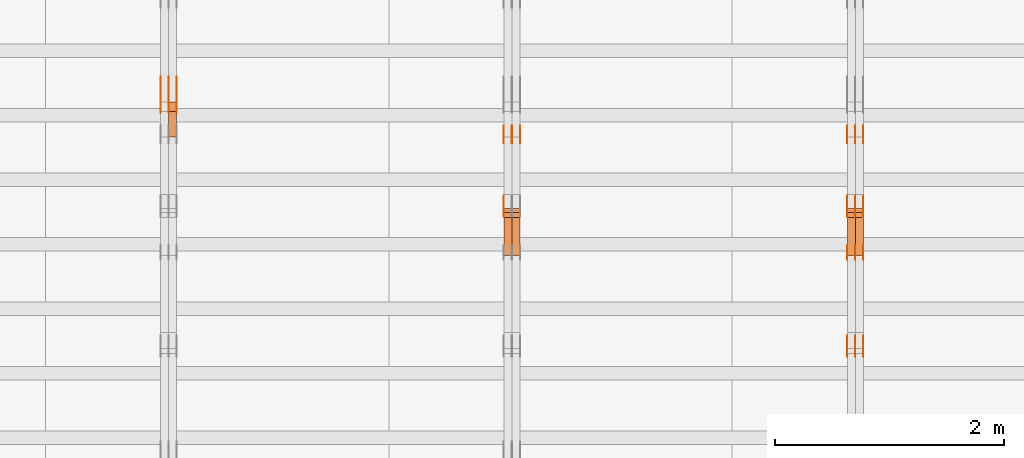
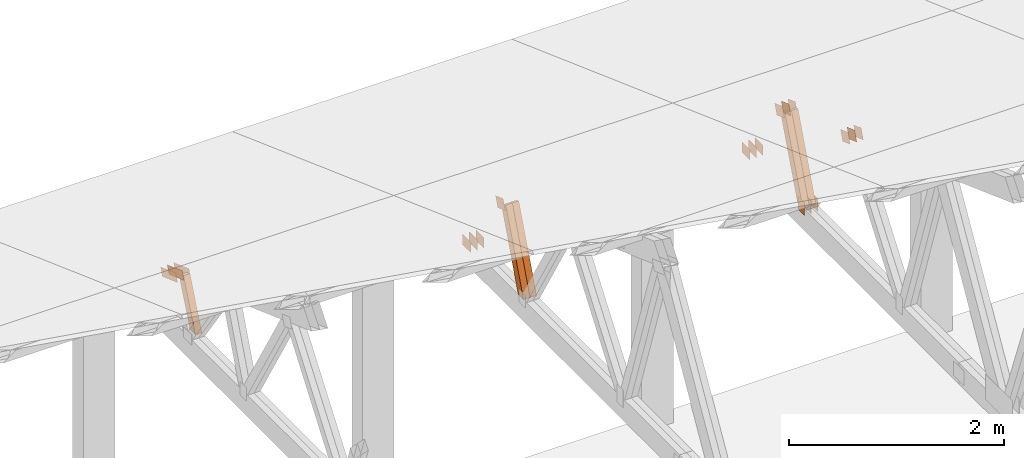
# One storey, part 133 of 189: 30 proxies.
"""IFC2X3 building model written with IfcOpenShell, lengths in millimetres."""

from ifc_helpers import new_model, entity, si_unit, converted_unit, derived_unit, direction, frame, frame_2d, origin, origin_2d_with_axis, place, context, subcontext, project, spatial, polyline, rectangle, outline, extrude, source, transform, mapped, material, type_object, type_shapes, element, save


model = new_model("IFC2X3")

# Units and contexts
model_context = context("Model", 3, precision=0.01, world=origin(), true_north=direction((6.12303176911189e-17, 1.0)))
body_context = subcontext(model_context, "Body", "Model", "MODEL_VIEW")
ifc_project = project(units=[si_unit("LENGTHUNIT", "METRE", prefix="MILLI"), si_unit("AREAUNIT", "SQUARE_METRE"), si_unit("VOLUMEUNIT", "CUBIC_METRE"), converted_unit("PLANEANGLEUNIT", "DEGREE", entity("IfcRatioMeasure", 0.0174532925199433), si_unit("PLANEANGLEUNIT", "RADIAN"), dimensions=[0, 0, 0, 0, 0, 0, 0]), si_unit("MASSUNIT", "GRAM", prefix="KILO"), derived_unit("MASSDENSITYUNIT", [(si_unit("MASSUNIT", "GRAM", prefix="KILO"), 1), (si_unit("LENGTHUNIT", "METRE"), -3)]), si_unit("TIMEUNIT", "SECOND"), si_unit("FREQUENCYUNIT", "HERTZ"), si_unit("THERMODYNAMICTEMPERATUREUNIT", "DEGREE_CELSIUS"), derived_unit("THERMALTRANSMITTANCEUNIT", [(si_unit("MASSUNIT", "GRAM", prefix="KILO"), 1), (si_unit("THERMODYNAMICTEMPERATUREUNIT", "KELVIN"), -1), (si_unit("TIMEUNIT", "SECOND"), -3)]), derived_unit("VOLUMETRICFLOWRATEUNIT", [(si_unit("LENGTHUNIT", "METRE"), 3), (si_unit("TIMEUNIT", "SECOND"), -1)]), si_unit("ELECTRICCURRENTUNIT", "AMPERE"), si_unit("ELECTRICVOLTAGEUNIT", "VOLT"), si_unit("POWERUNIT", "WATT"), si_unit("FORCEUNIT", "NEWTON"), si_unit("ILLUMINANCEUNIT", "LUX"), si_unit("LUMINOUSFLUXUNIT", "LUMEN"), si_unit("LUMINOUSINTENSITYUNIT", "CANDELA"), derived_unit("USERDEFINED", [(si_unit("MASSUNIT", "GRAM", prefix="KILO"), -1), (si_unit("LENGTHUNIT", "METRE"), -2), (si_unit("TIMEUNIT", "SECOND"), 3), (si_unit("LUMINOUSFLUXUNIT", "LUMEN"), 1)]), derived_unit("LINEARVELOCITYUNIT", [(si_unit("LENGTHUNIT", "METRE"), 1), (si_unit("TIMEUNIT", "SECOND"), -1)]), si_unit("PRESSUREUNIT", "PASCAL"), derived_unit("USERDEFINED", [(si_unit("LENGTHUNIT", "METRE"), -2), (si_unit("MASSUNIT", "GRAM", prefix="KILO"), 1), (si_unit("TIMEUNIT", "SECOND"), -2)])], contexts=[model_context])

# Site, building, storey
site_placement = place(None, origin())
site = spatial("IfcSite", under=ifc_project, at=site_placement, CompositionType="ELEMENT")
building_placement = place(site_placement, origin())
building = spatial("IfcBuilding", under=site, at=building_placement, CompositionType="ELEMENT")
storey_placement = place(building_placement, origin())
storey = spatial("IfcBuildingStorey", under=building, at=storey_placement, Name="Default", CompositionType="ELEMENT", Elevation=0.0)

# Proxies
ifc_material_1 = material(Name="IfcSurfaceStyle #168726")
building_element_proxy_type_1 = type_object("IfcBuildingElementProxyType", PredefinedType="NOTDEFINED", material=ifc_material_1)
shared_shape_1 = source(origin(), body_context, "Body", "SweptSolid", [
    extrude(outline(polyline([(-74.9999475298494, -60.0), (75.0000042257432, -60.0), (74.9999684051025, 60.0), (-75.0000251009963, 60.0), (-74.9999475298494, -60.0)])), frame((75.0000607644577, 60.0000865490217, 0.0), z_axis=(0.0, 0.0, 1.0), x_axis=(-1.0, 0.0, 0.0)), (0.0, 0.0, 1.0), 1.3),
])
type_shapes(building_element_proxy_type_1, [shared_shape_1])
proxy_1_placement = place(building_placement, frame((30301.3, 25732.0586805394, 1446.84420669249), z_axis=(-1.0, 0.0, 0.0), x_axis=(0.0, -0.939692620785908, 0.342020143325669)))
element("IfcBuildingElementProxy", 1, at=proxy_1_placement, inside=storey, type_object=building_element_proxy_type_1, material=ifc_material_1, context=body_context, shape_type="MappedRepresentation", body=[
    mapped(shared_shape_1, transform((0.0, 0.0, 0.0), scale=1.0)),
])
ifc_material_2 = material(Name="IfcSurfaceStyle #168669")
building_element_proxy_type_2 = type_object("IfcBuildingElementProxyType", PredefinedType="NOTDEFINED", material=ifc_material_2)
shared_shape_2 = source(origin(), body_context, "Body", "SweptSolid", [
    extrude(outline(polyline([(-74.9999475298494, -60.0), (75.0000042257432, -60.0), (74.9999684051025, 60.0), (-75.0000251009963, 60.0), (-74.9999475298494, -60.0)])), frame((75.0000607644577, 60.0000865490217, 0.0), z_axis=(0.0, 0.0, 1.0), x_axis=(-1.0, 0.0, 0.0)), (0.0, 0.0, 1.0), 1.29999999999999),
])
type_shapes(building_element_proxy_type_2, [shared_shape_2])
proxy_2_placement = place(building_placement, frame((30230.0, 25732.0586805394, 1446.84420669249), z_axis=(-1.0, 0.0, 0.0), x_axis=(0.0, -0.939692620785908, 0.342020143325669)))
element("IfcBuildingElementProxy", 2, at=proxy_2_placement, inside=storey, type_object=building_element_proxy_type_2, material=ifc_material_2, context=body_context, shape_type="MappedRepresentation", body=[
    mapped(shared_shape_2, transform((0.0, 0.0, 0.0), scale=1.0)),
])
ifc_material_3 = material(Name="IfcSurfaceStyle #168612")
building_element_proxy_type_3 = type_object("IfcBuildingElementProxyType", PredefinedType="NOTDEFINED", material=ifc_material_3)
shared_shape_3 = source(origin(), body_context, "Body", "SweptSolid", [
    extrude(outline(polyline([(-74.9999475298494, -60.0), (75.0000042257432, -60.0), (74.9999684051025, 60.0), (-75.0000251009963, 60.0), (-74.9999475298494, -60.0)])), frame((75.0000607644577, 60.0000865490217, 0.0), z_axis=(0.0, 0.0, 1.0), x_axis=(-1.0, 0.0, 0.0)), (0.0, 0.0, 1.0), 1.29999999999999),
])
type_shapes(building_element_proxy_type_3, [shared_shape_3])
proxy_3_placement = place(building_placement, frame((30231.3, 25732.0586805394, 1446.84420669249), z_axis=(-1.0, 0.0, 0.0), x_axis=(0.0, -0.939692620785908, 0.342020143325669)))
element("IfcBuildingElementProxy", 3, at=proxy_3_placement, inside=storey, type_object=building_element_proxy_type_3, material=ifc_material_3, context=body_context, shape_type="MappedRepresentation", body=[
    mapped(shared_shape_3, transform((0.0, 0.0, 0.0), scale=1.0)),
])
ifc_material_4 = material(Name="IfcSurfaceStyle #168555")
building_element_proxy_type_4 = type_object("IfcBuildingElementProxyType", PredefinedType="NOTDEFINED", material=ifc_material_4)
shared_shape_4 = source(origin(), body_context, "Body", "SweptSolid", [
    extrude(outline(polyline([(-74.9999475298494, -60.0), (75.0000042257432, -60.0), (74.9999684051025, 60.0), (-75.0000251009963, 60.0), (-74.9999475298494, -60.0)])), frame((75.0000607644577, 60.0000865490217, 0.0), z_axis=(0.0, 0.0, 1.0), x_axis=(-1.0, 0.0, 0.0)), (0.0, 0.0, 1.0), 1.29999999999999),
])
type_shapes(building_element_proxy_type_4, [shared_shape_4])
proxy_4_placement = place(building_placement, frame((30160.0, 25732.0586805394, 1446.84420669249), z_axis=(-1.0, 0.0, 0.0), x_axis=(0.0, -0.939692620785908, 0.342020143325669)))
element("IfcBuildingElementProxy", 4, at=proxy_4_placement, inside=storey, type_object=building_element_proxy_type_4, material=ifc_material_4, context=body_context, shape_type="MappedRepresentation", body=[
    mapped(shared_shape_4, transform((0.0, 0.0, 0.0), scale=1.0)),
])
ifc_material_5 = material(Name="IfcSurfaceStyle #168498")
building_element_proxy_type_5 = type_object("IfcBuildingElementProxyType", PredefinedType="NOTDEFINED", material=ifc_material_5)
shared_shape_5 = source(origin(), body_context, "Body", "SweptSolid", [
    extrude(rectangle(XDim=150.0, YDim=120.0, at=frame_2d((-7.105427357601e-15, 0.0), x_axis=(1.0, 0.0))), frame((75.0, 60.0, 0.0), z_axis=(0.0, 0.0, 1.0), x_axis=(-1.0, 0.0, 0.0)), (0.0, 0.0, 1.0), 1.3),
])
type_shapes(building_element_proxy_type_5, [shared_shape_5])
proxy_5_placement = place(building_placement, frame((30301.3, 26439.0083007813, 170.0), z_axis=(-1.0, 0.0, 0.0), x_axis=(0.0, 0.0, 1.0)))
element("IfcBuildingElementProxy", 5, at=proxy_5_placement, inside=storey, type_object=building_element_proxy_type_5, material=ifc_material_5, context=body_context, shape_type="MappedRepresentation", body=[
    mapped(shared_shape_5, transform((0.0, 0.0, 0.0), scale=1.0)),
])
ifc_material_6 = material(Name="IfcSurfaceStyle #168441")
building_element_proxy_type_6 = type_object("IfcBuildingElementProxyType", PredefinedType="NOTDEFINED", material=ifc_material_6)
shared_shape_6 = source(origin(), body_context, "Body", "SweptSolid", [
    extrude(rectangle(XDim=150.0, YDim=120.0, at=frame_2d((-7.105427357601e-15, 0.0), x_axis=(1.0, 0.0))), frame((75.0, 60.0, 0.0), z_axis=(0.0, 0.0, 1.0), x_axis=(-1.0, 0.0, 0.0)), (0.0, 0.0, 1.0), 1.29999999999999),
])
type_shapes(building_element_proxy_type_6, [shared_shape_6])
proxy_6_placement = place(building_placement, frame((30230.0, 26439.0083007813, 170.0), z_axis=(-1.0, 0.0, 0.0), x_axis=(0.0, 0.0, 1.0)))
element("IfcBuildingElementProxy", 6, at=proxy_6_placement, inside=storey, type_object=building_element_proxy_type_6, material=ifc_material_6, context=body_context, shape_type="MappedRepresentation", body=[
    mapped(shared_shape_6, transform((0.0, 0.0, 0.0), scale=1.0)),
])
ifc_material_7 = material(Name="IfcSurfaceStyle #168384")
building_element_proxy_type_7 = type_object("IfcBuildingElementProxyType", PredefinedType="NOTDEFINED", material=ifc_material_7)
shared_shape_7 = source(origin(), body_context, "Body", "SweptSolid", [
    extrude(rectangle(XDim=150.0, YDim=120.0, at=frame_2d((-7.105427357601e-15, 0.0), x_axis=(1.0, 0.0))), frame((75.0, 60.0, 0.0), z_axis=(0.0, 0.0, 1.0), x_axis=(-1.0, 0.0, 0.0)), (0.0, 0.0, 1.0), 1.29999999999999),
])
type_shapes(building_element_proxy_type_7, [shared_shape_7])
proxy_7_placement = place(building_placement, frame((30231.3, 26439.0083007813, 170.0), z_axis=(-1.0, 0.0, 0.0), x_axis=(0.0, 0.0, 1.0)))
element("IfcBuildingElementProxy", 7, at=proxy_7_placement, inside=storey, type_object=building_element_proxy_type_7, material=ifc_material_7, context=body_context, shape_type="MappedRepresentation", body=[
    mapped(shared_shape_7, transform((0.0, 0.0, 0.0), scale=1.0)),
])
ifc_material_8 = material(Name="IfcSurfaceStyle #168327")
building_element_proxy_type_8 = type_object("IfcBuildingElementProxyType", PredefinedType="NOTDEFINED", material=ifc_material_8)
shared_shape_8 = source(origin(), body_context, "Body", "SweptSolid", [
    extrude(rectangle(XDim=150.0, YDim=120.0, at=frame_2d((-7.105427357601e-15, 0.0), x_axis=(1.0, 0.0))), frame((75.0, 60.0, 0.0), z_axis=(0.0, 0.0, 1.0), x_axis=(-1.0, 0.0, 0.0)), (0.0, 0.0, 1.0), 1.29999999999999),
])
type_shapes(building_element_proxy_type_8, [shared_shape_8])
proxy_8_placement = place(building_placement, frame((30160.0, 26439.0083007813, 170.0), z_axis=(-1.0, 0.0, 0.0), x_axis=(0.0, 0.0, 1.0)))
element("IfcBuildingElementProxy", 8, at=proxy_8_placement, inside=storey, type_object=building_element_proxy_type_8, material=ifc_material_8, context=body_context, shape_type="MappedRepresentation", body=[
    mapped(shared_shape_8, transform((0.0, 0.0, 0.0), scale=1.0)),
])
ifc_material_9 = material(Name="IfcSurfaceStyle #167814")
building_element_proxy_type_9 = type_object("IfcBuildingElementProxyType", PredefinedType="NOTDEFINED", material=ifc_material_9)
shared_shape_9 = source(origin(), body_context, "Body", "SweptSolid", [
    extrude(outline(polyline([(-74.9999684051023, -60.0), (75.0000251009964, -60.0), (74.9999475298495, 60.0), (-75.0000042257435, 60.0), (-74.9999684051023, -60.0)])), frame((75.0000251009964, 60.0000006265238, 0.0), z_axis=(0.0, 0.0, 1.0), x_axis=(-1.0, 0.0, 0.0)), (0.0, 0.0, 1.0), 1.3),
])
type_shapes(building_element_proxy_type_9, [shared_shape_9])
proxy_9_placement = place(building_placement, frame((30301.3, 26956.490053282, 1001.18769055967), z_axis=(-1.0, 0.0, 0.0), x_axis=(0.0, -0.939692620785908, 0.342020143325669)))
element("IfcBuildingElementProxy", 9, at=proxy_9_placement, inside=storey, type_object=building_element_proxy_type_9, material=ifc_material_9, context=body_context, shape_type="MappedRepresentation", body=[
    mapped(shared_shape_9, transform((0.0, 0.0, 0.0), scale=1.0)),
])
ifc_material_10 = material(Name="IfcSurfaceStyle #167757")
building_element_proxy_type_10 = type_object("IfcBuildingElementProxyType", PredefinedType="NOTDEFINED", material=ifc_material_10)
shared_shape_10 = source(origin(), body_context, "Body", "SweptSolid", [
    extrude(outline(polyline([(-74.9999684051023, -60.0), (75.0000251009964, -60.0), (74.9999475298495, 60.0), (-75.0000042257435, 60.0), (-74.9999684051023, -60.0)])), frame((75.0000251009964, 60.0000006265238, 0.0), z_axis=(0.0, 0.0, 1.0), x_axis=(-1.0, 0.0, 0.0)), (0.0, 0.0, 1.0), 1.29999999999999),
])
type_shapes(building_element_proxy_type_10, [shared_shape_10])
proxy_10_placement = place(building_placement, frame((30230.0, 26956.490053282, 1001.18769055967), z_axis=(-1.0, 0.0, 0.0), x_axis=(0.0, -0.939692620785908, 0.342020143325669)))
element("IfcBuildingElementProxy", 10, at=proxy_10_placement, inside=storey, type_object=building_element_proxy_type_10, material=ifc_material_10, context=body_context, shape_type="MappedRepresentation", body=[
    mapped(shared_shape_10, transform((0.0, 0.0, 0.0), scale=1.0)),
])
ifc_material_11 = material(Name="IfcSurfaceStyle #167700")
building_element_proxy_type_11 = type_object("IfcBuildingElementProxyType", PredefinedType="NOTDEFINED", material=ifc_material_11)
shared_shape_11 = source(origin(), body_context, "Body", "SweptSolid", [
    extrude(outline(polyline([(-74.9999684051023, -60.0), (75.0000251009964, -60.0), (74.9999475298495, 60.0), (-75.0000042257435, 60.0), (-74.9999684051023, -60.0)])), frame((75.0000251009964, 60.0000006265238, 0.0), z_axis=(0.0, 0.0, 1.0), x_axis=(-1.0, 0.0, 0.0)), (0.0, 0.0, 1.0), 1.29999999999999),
])
type_shapes(building_element_proxy_type_11, [shared_shape_11])
proxy_11_placement = place(building_placement, frame((30231.3, 26956.490053282, 1001.18769055967), z_axis=(-1.0, 0.0, 0.0), x_axis=(0.0, -0.939692620785908, 0.342020143325669)))
element("IfcBuildingElementProxy", 11, at=proxy_11_placement, inside=storey, type_object=building_element_proxy_type_11, material=ifc_material_11, context=body_context, shape_type="MappedRepresentation", body=[
    mapped(shared_shape_11, transform((0.0, 0.0, 0.0), scale=1.0)),
])
ifc_material_12 = material(Name="IfcSurfaceStyle #167643")
building_element_proxy_type_12 = type_object("IfcBuildingElementProxyType", PredefinedType="NOTDEFINED", material=ifc_material_12)
shared_shape_12 = source(origin(), body_context, "Body", "SweptSolid", [
    extrude(outline(polyline([(-74.9999684051023, -60.0), (75.0000251009964, -60.0), (74.9999475298495, 60.0), (-75.0000042257435, 60.0), (-74.9999684051023, -60.0)])), frame((75.0000251009964, 60.0000006265238, 0.0), z_axis=(0.0, 0.0, 1.0), x_axis=(-1.0, 0.0, 0.0)), (0.0, 0.0, 1.0), 1.29999999999999),
])
type_shapes(building_element_proxy_type_12, [shared_shape_12])
proxy_12_placement = place(building_placement, frame((30160.0, 26956.490053282, 1001.18769055967), z_axis=(-1.0, 0.0, 0.0), x_axis=(0.0, -0.939692620785908, 0.342020143325669)))
element("IfcBuildingElementProxy", 12, at=proxy_12_placement, inside=storey, type_object=building_element_proxy_type_12, material=ifc_material_12, context=body_context, shape_type="MappedRepresentation", body=[
    mapped(shared_shape_12, transform((0.0, 0.0, 0.0), scale=1.0)),
])
ifc_material_13 = material(Name="IfcSurfaceStyle #167586")
building_element_proxy_type_13 = type_object("IfcBuildingElementProxyType", PredefinedType="NOTDEFINED", material=ifc_material_13)
shared_shape_13 = source(origin(), body_context, "Body", "SweptSolid", [
    extrude(rectangle(XDim=150.0, YDim=120.0, at=origin_2d_with_axis()), frame((75.0, 60.0, 0.0), z_axis=(0.0, 0.0, 1.0), x_axis=(-1.0, 0.0, 0.0)), (0.0, 0.0, 1.0), 1.3),
])
type_shapes(building_element_proxy_type_13, [shared_shape_13])
proxy_13_placement = place(building_placement, frame((30301.3, 27607.3129882813, 185.0), z_axis=(-1.0, 0.0, 0.0), x_axis=(0.0, -1.0, 0.0)))
element("IfcBuildingElementProxy", 13, at=proxy_13_placement, inside=storey, type_object=building_element_proxy_type_13, material=ifc_material_13, context=body_context, shape_type="MappedRepresentation", body=[
    mapped(shared_shape_13, transform((0.0, 0.0, 0.0), scale=1.0)),
])
ifc_material_14 = material(Name="IfcSurfaceStyle #167529")
building_element_proxy_type_14 = type_object("IfcBuildingElementProxyType", PredefinedType="NOTDEFINED", material=ifc_material_14)
shared_shape_14 = source(origin(), body_context, "Body", "SweptSolid", [
    extrude(rectangle(XDim=150.0, YDim=120.0, at=origin_2d_with_axis()), frame((75.0, 60.0, 0.0), z_axis=(0.0, 0.0, 1.0), x_axis=(-1.0, 0.0, 0.0)), (0.0, 0.0, 1.0), 1.29999999999999),
])
type_shapes(building_element_proxy_type_14, [shared_shape_14])
proxy_14_placement = place(building_placement, frame((30230.0, 27607.3129882813, 185.0), z_axis=(-1.0, 0.0, 0.0), x_axis=(0.0, -1.0, 0.0)))
element("IfcBuildingElementProxy", 14, at=proxy_14_placement, inside=storey, type_object=building_element_proxy_type_14, material=ifc_material_14, context=body_context, shape_type="MappedRepresentation", body=[
    mapped(shared_shape_14, transform((0.0, 0.0, 0.0), scale=1.0)),
])
ifc_material_15 = material(Name="IfcSurfaceStyle #167472")
building_element_proxy_type_15 = type_object("IfcBuildingElementProxyType", PredefinedType="NOTDEFINED", material=ifc_material_15)
shared_shape_15 = source(origin(), body_context, "Body", "SweptSolid", [
    extrude(rectangle(XDim=150.0, YDim=120.0, at=origin_2d_with_axis()), frame((75.0, 60.0, 0.0), z_axis=(0.0, 0.0, 1.0), x_axis=(-1.0, 0.0, 0.0)), (0.0, 0.0, 1.0), 1.29999999999999),
])
type_shapes(building_element_proxy_type_15, [shared_shape_15])
proxy_15_placement = place(building_placement, frame((30231.3, 27607.3129882813, 185.0), z_axis=(-1.0, 0.0, 0.0), x_axis=(0.0, -1.0, 0.0)))
element("IfcBuildingElementProxy", 15, at=proxy_15_placement, inside=storey, type_object=building_element_proxy_type_15, material=ifc_material_15, context=body_context, shape_type="MappedRepresentation", body=[
    mapped(shared_shape_15, transform((0.0, 0.0, 0.0), scale=1.0)),
])
ifc_material_16 = material(Name="IfcSurfaceStyle #167415")
building_element_proxy_type_16 = type_object("IfcBuildingElementProxyType", PredefinedType="NOTDEFINED", material=ifc_material_16)
shared_shape_16 = source(origin(), body_context, "Body", "SweptSolid", [
    extrude(rectangle(XDim=150.0, YDim=120.0, at=origin_2d_with_axis()), frame((75.0, 60.0, 0.0), z_axis=(0.0, 0.0, 1.0), x_axis=(-1.0, 0.0, 0.0)), (0.0, 0.0, 1.0), 1.29999999999999),
])
type_shapes(building_element_proxy_type_16, [shared_shape_16])
proxy_16_placement = place(building_placement, frame((30160.0, 27607.3129882813, 185.0), z_axis=(-1.0, 0.0, 0.0), x_axis=(0.0, -1.0, 0.0)))
element("IfcBuildingElementProxy", 16, at=proxy_16_placement, inside=storey, type_object=building_element_proxy_type_16, material=ifc_material_16, context=body_context, shape_type="MappedRepresentation", body=[
    mapped(shared_shape_16, transform((0.0, 0.0, 0.0), scale=1.0)),
])
ifc_material_17 = material(Name="IfcSurfaceStyle #160338")
building_element_proxy_type_17 = type_object("IfcBuildingElementProxyType", Name="T1-W14 160336", PredefinedType="NOTDEFINED", material=ifc_material_17)
shared_shape_17 = source(origin(), body_context, "Body", "SweptSolid", [
    extrude(outline(polyline([(-561.981237417233, -47.499947472121), (373.092610496013, -47.499947472121), (373.679602940405, -4.61719047935016e-05), (341.277449358876, 47.4999705580734), (-526.068425378061, 47.4999705580734), (-561.981237417233, -47.499947472121)])), frame((373.679632439416, 47.500120814091, 0.0), z_axis=(0.0, 0.0, 1.0), x_axis=(-1.0, 0.0, 0.0)), (0.0, 0.0, 1.0), 69.9999999999999),
])
type_shapes(building_element_proxy_type_17, [shared_shape_17])
proxy_17_placement = place(building_placement, frame((30300.0, 26895.4809555667, 1086.61918844835), z_axis=(-1.0, 0.0, 0.0), x_axis=(0.0, -0.353606472447933, -0.935394281916951)))
element("IfcBuildingElementProxy", 17, at=proxy_17_placement, inside=storey, type_object=building_element_proxy_type_17, material=ifc_material_17, Name="T1-W14", context=body_context, shape_type="MappedRepresentation", body=[
    mapped(shared_shape_17, transform((0.0, 0.0, 0.0), scale=1.0)),
])
ifc_material_18 = material(Name="IfcSurfaceStyle #160272")
building_element_proxy_type_18 = type_object("IfcBuildingElementProxyType", Name="T1-W14 160270", PredefinedType="NOTDEFINED", material=ifc_material_18)
shared_shape_18 = source(origin(), body_context, "Body", "SweptSolid", [
    extrude(outline(polyline([(-561.981237417233, -47.499947472121), (373.092610496013, -47.499947472121), (373.679602940405, -4.61719047935016e-05), (341.277449358876, 47.4999705580734), (-526.068425378061, 47.4999705580734), (-561.981237417233, -47.499947472121)])), frame((373.679632439416, 47.500120814091, 0.0), z_axis=(0.0, 0.0, 1.0), x_axis=(-1.0, 0.0, 0.0)), (0.0, 0.0, 1.0), 69.9999999999999),
])
type_shapes(building_element_proxy_type_18, [shared_shape_18])
proxy_18_placement = place(building_placement, frame((30230.0, 26895.4809555667, 1086.61918844835), z_axis=(-1.0, 0.0, 0.0), x_axis=(0.0, -0.353606472447933, -0.935394281916951)))
element("IfcBuildingElementProxy", 18, at=proxy_18_placement, inside=storey, type_object=building_element_proxy_type_18, material=ifc_material_18, Name="T1-W14", context=body_context, shape_type="MappedRepresentation", body=[
    mapped(shared_shape_18, transform((0.0, 0.0, 0.0), scale=1.0)),
])
ifc_material_19 = material(Name="IfcSurfaceStyle #151853")
building_element_proxy_type_19 = type_object("IfcBuildingElementProxyType", PredefinedType="NOTDEFINED", material=ifc_material_19)
shared_shape_19 = source(origin(), body_context, "Body", "SweptSolid", [
    extrude(outline(polyline([(-74.9999684051023, -60.0), (75.0000251009964, -60.0), (74.9999475298495, 60.0), (-75.0000042257435, 60.0), (-74.9999684051023, -60.0)])), frame((75.0000251009964, 60.0000006265238, 0.0), z_axis=(0.0, 0.0, 1.0), x_axis=(-1.0, 0.0, 0.0)), (0.0, 0.0, 1.0), 1.29999999999999),
])
type_shapes(building_element_proxy_type_19, [shared_shape_19])
proxy_19_placement = place(building_placement, frame((27160.0, 26956.490053282, 1001.18769055967), z_axis=(-1.0, 0.0, 0.0), x_axis=(0.0, -0.939692620785908, 0.342020143325669)))
element("IfcBuildingElementProxy", 19, at=proxy_19_placement, inside=storey, type_object=building_element_proxy_type_19, material=ifc_material_19, context=body_context, shape_type="MappedRepresentation", body=[
    mapped(shared_shape_19, transform((0.0, 0.0, 0.0), scale=1.0)),
])
ifc_material_20 = material(Name="IfcSurfaceStyle #151796")
building_element_proxy_type_20 = type_object("IfcBuildingElementProxyType", PredefinedType="NOTDEFINED", material=ifc_material_20)
shared_shape_20 = source(origin(), body_context, "Body", "SweptSolid", [
    extrude(rectangle(XDim=150.0, YDim=120.0, at=origin_2d_with_axis()), frame((75.0, 60.0, 0.0), z_axis=(0.0, 0.0, 1.0), x_axis=(-1.0, 0.0, 0.0)), (0.0, 0.0, 1.0), 1.3),
])
type_shapes(building_element_proxy_type_20, [shared_shape_20])
proxy_20_placement = place(building_placement, frame((27301.3, 27607.3129882813, 185.0), z_axis=(-1.0, 0.0, 0.0), x_axis=(0.0, -1.0, 0.0)))
element("IfcBuildingElementProxy", 20, at=proxy_20_placement, inside=storey, type_object=building_element_proxy_type_20, material=ifc_material_20, context=body_context, shape_type="MappedRepresentation", body=[
    mapped(shared_shape_20, transform((0.0, 0.0, 0.0), scale=1.0)),
])
ifc_material_21 = material(Name="IfcSurfaceStyle #151739")
building_element_proxy_type_21 = type_object("IfcBuildingElementProxyType", PredefinedType="NOTDEFINED", material=ifc_material_21)
shared_shape_21 = source(origin(), body_context, "Body", "SweptSolid", [
    extrude(rectangle(XDim=150.0, YDim=120.0, at=origin_2d_with_axis()), frame((75.0, 60.0, 0.0), z_axis=(0.0, 0.0, 1.0), x_axis=(-1.0, 0.0, 0.0)), (0.0, 0.0, 1.0), 1.29999999999999),
])
type_shapes(building_element_proxy_type_21, [shared_shape_21])
proxy_21_placement = place(building_placement, frame((27230.0, 27607.3129882813, 185.0), z_axis=(-1.0, 0.0, 0.0), x_axis=(0.0, -1.0, 0.0)))
element("IfcBuildingElementProxy", 21, at=proxy_21_placement, inside=storey, type_object=building_element_proxy_type_21, material=ifc_material_21, context=body_context, shape_type="MappedRepresentation", body=[
    mapped(shared_shape_21, transform((0.0, 0.0, 0.0), scale=1.0)),
])
ifc_material_22 = material(Name="IfcSurfaceStyle #151682")
building_element_proxy_type_22 = type_object("IfcBuildingElementProxyType", PredefinedType="NOTDEFINED", material=ifc_material_22)
shared_shape_22 = source(origin(), body_context, "Body", "SweptSolid", [
    extrude(rectangle(XDim=150.0, YDim=120.0, at=origin_2d_with_axis()), frame((75.0, 60.0, 0.0), z_axis=(0.0, 0.0, 1.0), x_axis=(-1.0, 0.0, 0.0)), (0.0, 0.0, 1.0), 1.29999999999999),
])
type_shapes(building_element_proxy_type_22, [shared_shape_22])
proxy_22_placement = place(building_placement, frame((27231.3, 27607.3129882813, 185.0), z_axis=(-1.0, 0.0, 0.0), x_axis=(0.0, -1.0, 0.0)))
element("IfcBuildingElementProxy", 22, at=proxy_22_placement, inside=storey, type_object=building_element_proxy_type_22, material=ifc_material_22, context=body_context, shape_type="MappedRepresentation", body=[
    mapped(shared_shape_22, transform((0.0, 0.0, 0.0), scale=1.0)),
])
ifc_material_23 = material(Name="IfcSurfaceStyle #151625")
building_element_proxy_type_23 = type_object("IfcBuildingElementProxyType", PredefinedType="NOTDEFINED", material=ifc_material_23)
shared_shape_23 = source(origin(), body_context, "Body", "SweptSolid", [
    extrude(rectangle(XDim=150.0, YDim=120.0, at=origin_2d_with_axis()), frame((75.0, 60.0, 0.0), z_axis=(0.0, 0.0, 1.0), x_axis=(-1.0, 0.0, 0.0)), (0.0, 0.0, 1.0), 1.29999999999999),
])
type_shapes(building_element_proxy_type_23, [shared_shape_23])
proxy_23_placement = place(building_placement, frame((27160.0, 27607.3129882813, 185.0), z_axis=(-1.0, 0.0, 0.0), x_axis=(0.0, -1.0, 0.0)))
element("IfcBuildingElementProxy", 23, at=proxy_23_placement, inside=storey, type_object=building_element_proxy_type_23, material=ifc_material_23, context=body_context, shape_type="MappedRepresentation", body=[
    mapped(shared_shape_23, transform((0.0, 0.0, 0.0), scale=1.0)),
])
ifc_material_24 = material(Name="IfcSurfaceStyle #144548")
building_element_proxy_type_24 = type_object("IfcBuildingElementProxyType", Name="T1-W14 144546", PredefinedType="NOTDEFINED", material=ifc_material_24)
shared_shape_24 = source(origin(), body_context, "Body", "SweptSolid", [
    extrude(outline(polyline([(-561.981237417233, -47.499947472121), (373.092610496013, -47.499947472121), (373.679602940405, -4.61719047935016e-05), (341.277449358876, 47.4999705580734), (-526.068425378061, 47.4999705580734), (-561.981237417233, -47.499947472121)])), frame((373.679632439416, 47.500120814091, 0.0), z_axis=(0.0, 0.0, 1.0), x_axis=(-1.0, 0.0, 0.0)), (0.0, 0.0, 1.0), 69.9999999999999),
])
type_shapes(building_element_proxy_type_24, [shared_shape_24])
proxy_24_placement = place(building_placement, frame((27300.0, 26895.4809555667, 1086.61918844835), z_axis=(-1.0, 0.0, 0.0), x_axis=(0.0, -0.353606472447933, -0.935394281916951)))
element("IfcBuildingElementProxy", 24, at=proxy_24_placement, inside=storey, type_object=building_element_proxy_type_24, material=ifc_material_24, Name="T1-W14", context=body_context, shape_type="MappedRepresentation", body=[
    mapped(shared_shape_24, transform((0.0, 0.0, 0.0), scale=1.0)),
])
ifc_material_25 = material(Name="IfcSurfaceStyle #144482")
building_element_proxy_type_25 = type_object("IfcBuildingElementProxyType", Name="T1-W14 144480", PredefinedType="NOTDEFINED", material=ifc_material_25)
shared_shape_25 = source(origin(), body_context, "Body", "SweptSolid", [
    extrude(outline(polyline([(-561.981237417233, -47.499947472121), (373.092610496013, -47.499947472121), (373.679602940405, -4.61719047935016e-05), (341.277449358876, 47.4999705580734), (-526.068425378061, 47.4999705580734), (-561.981237417233, -47.499947472121)])), frame((373.679632439416, 47.500120814091, 0.0), z_axis=(0.0, 0.0, 1.0), x_axis=(-1.0, 0.0, 0.0)), (0.0, 0.0, 1.0), 69.9999999999999),
])
type_shapes(building_element_proxy_type_25, [shared_shape_25])
proxy_25_placement = place(building_placement, frame((27230.0, 26895.4809555667, 1086.61918844835), z_axis=(-1.0, 0.0, 0.0), x_axis=(0.0, -0.353606472447933, -0.935394281916951)))
element("IfcBuildingElementProxy", 25, at=proxy_25_placement, inside=storey, type_object=building_element_proxy_type_25, material=ifc_material_25, Name="T1-W14", context=body_context, shape_type="MappedRepresentation", body=[
    mapped(shared_shape_25, transform((0.0, 0.0, 0.0), scale=1.0)),
])
ifc_material_26 = material(Name="IfcSurfaceStyle #135322")
building_element_proxy_type_26 = type_object("IfcBuildingElementProxyType", PredefinedType="NOTDEFINED", material=ifc_material_26)
shared_shape_26 = source(origin(), body_context, "Body", "SweptSolid", [
    extrude(outline(polyline([(-150.000004175486, -48.0000091256405), (150.000055794777, -48.0000091256405), (149.99999373786, 48.0000091256405), (-150.000045357151, 48.0000091256405), (-150.000004175486, -48.0000091256405)])), frame((150.000055794777, 48.0000091256405, 0.0), z_axis=(0.0, 0.0, 1.0), x_axis=(-1.0, 0.0, 0.0)), (0.0, 0.0, 1.0), 1.29999999999999),
])
type_shapes(building_element_proxy_type_26, [shared_shape_26])
proxy_26_placement = place(building_placement, frame((24301.3, 28002.7008500375, 633.16821439849), z_axis=(-1.0, 0.0, 0.0), x_axis=(0.0, -0.939692620785908, 0.342020143325669)))
element("IfcBuildingElementProxy", 26, at=proxy_26_placement, inside=storey, type_object=building_element_proxy_type_26, material=ifc_material_26, context=body_context, shape_type="MappedRepresentation", body=[
    mapped(shared_shape_26, transform((0.0, 0.0, 0.0), scale=1.0)),
])
ifc_material_27 = material(Name="IfcSurfaceStyle #135265")
building_element_proxy_type_27 = type_object("IfcBuildingElementProxyType", PredefinedType="NOTDEFINED", material=ifc_material_27)
shared_shape_27 = source(origin(), body_context, "Body", "SweptSolid", [
    extrude(outline(polyline([(-150.000004175486, -48.0000091256405), (150.000055794777, -48.0000091256405), (149.99999373786, 48.0000091256405), (-150.000045357151, 48.0000091256405), (-150.000004175486, -48.0000091256405)])), frame((150.000055794777, 48.0000091256405, 0.0), z_axis=(0.0, 0.0, 1.0), x_axis=(-1.0, 0.0, 0.0)), (0.0, 0.0, 1.0), 1.29999999999998),
])
type_shapes(building_element_proxy_type_27, [shared_shape_27])
proxy_27_placement = place(building_placement, frame((24230.0, 28002.7008500375, 633.16821439849), z_axis=(-1.0, 0.0, 0.0), x_axis=(0.0, -0.939692620785908, 0.342020143325669)))
element("IfcBuildingElementProxy", 27, at=proxy_27_placement, inside=storey, type_object=building_element_proxy_type_27, material=ifc_material_27, context=body_context, shape_type="MappedRepresentation", body=[
    mapped(shared_shape_27, transform((0.0, 0.0, 0.0), scale=1.0)),
])
ifc_material_28 = material(Name="IfcSurfaceStyle #135208")
building_element_proxy_type_28 = type_object("IfcBuildingElementProxyType", PredefinedType="NOTDEFINED", material=ifc_material_28)
shared_shape_28 = source(origin(), body_context, "Body", "SweptSolid", [
    extrude(outline(polyline([(-150.000004175486, -48.0000091256405), (150.000055794777, -48.0000091256405), (149.99999373786, 48.0000091256405), (-150.000045357151, 48.0000091256405), (-150.000004175486, -48.0000091256405)])), frame((150.000055794777, 48.0000091256405, 0.0), z_axis=(0.0, 0.0, 1.0), x_axis=(-1.0, 0.0, 0.0)), (0.0, 0.0, 1.0), 1.29999999999998),
])
type_shapes(building_element_proxy_type_28, [shared_shape_28])
proxy_28_placement = place(building_placement, frame((24231.3, 28002.7008500375, 633.16821439849), z_axis=(-1.0, 0.0, 0.0), x_axis=(0.0, -0.939692620785908, 0.342020143325669)))
element("IfcBuildingElementProxy", 28, at=proxy_28_placement, inside=storey, type_object=building_element_proxy_type_28, material=ifc_material_28, context=body_context, shape_type="MappedRepresentation", body=[
    mapped(shared_shape_28, transform((0.0, 0.0, 0.0), scale=1.0)),
])
ifc_material_29 = material(Name="IfcSurfaceStyle #135151")
building_element_proxy_type_29 = type_object("IfcBuildingElementProxyType", PredefinedType="NOTDEFINED", material=ifc_material_29)
shared_shape_29 = source(origin(), body_context, "Body", "SweptSolid", [
    extrude(outline(polyline([(-150.000004175486, -48.0000091256405), (150.000055794777, -48.0000091256405), (149.99999373786, 48.0000091256405), (-150.000045357151, 48.0000091256405), (-150.000004175486, -48.0000091256405)])), frame((150.000055794777, 48.0000091256405, 0.0), z_axis=(0.0, 0.0, 1.0), x_axis=(-1.0, 0.0, 0.0)), (0.0, 0.0, 1.0), 1.29999999999998),
])
type_shapes(building_element_proxy_type_29, [shared_shape_29])
proxy_29_placement = place(building_placement, frame((24160.0, 28002.7008500375, 633.16821439849), z_axis=(-1.0, 0.0, 0.0), x_axis=(0.0, -0.939692620785908, 0.342020143325669)))
element("IfcBuildingElementProxy", 29, at=proxy_29_placement, inside=storey, type_object=building_element_proxy_type_29, material=ifc_material_29, context=body_context, shape_type="MappedRepresentation", body=[
    mapped(shared_shape_29, transform((0.0, 0.0, 0.0), scale=1.0)),
])
ifc_material_30 = material(Name="IfcSurfaceStyle #128230")
building_element_proxy_type_30 = type_object("IfcBuildingElementProxyType", Name="T1-W15 128228", PredefinedType="NOTDEFINED", material=ifc_material_30)
shared_shape_30 = source(origin(), body_context, "Body", "SweptSolid", [
    extrude(outline(polyline([(-356.314733086722, -47.5000181042257), (225.500284389883, -47.5000181042257), (227.502094104438, -2.00397075419828e-05), (220.445344962296, 47.5000281240794), (-317.132990369895, 47.5000281240795), (-356.314733086722, -47.5000181042257)])), frame((227.502118521083, 47.5000281240794, 0.0), z_axis=(0.0, 0.0, 1.0), x_axis=(-1.0, 0.0, 0.0)), (0.0, 0.0, 1.0), 70.0),
])
type_shapes(building_element_proxy_type_30, [shared_shape_30])
proxy_30_placement = place(building_placement, frame((24300.0, 27820.3452927615, 748.492381554869), z_axis=(-1.0, 0.0, 0.0), x_axis=(0.0, -0.38128326679549, -0.9244582578255)))
element("IfcBuildingElementProxy", 30, at=proxy_30_placement, inside=storey, type_object=building_element_proxy_type_30, material=ifc_material_30, Name="T1-W15", context=body_context, shape_type="MappedRepresentation", body=[
    mapped(shared_shape_30, transform((0.0, 0.0, 0.0), scale=1.0)),
])

save(model, "model.ifc")
